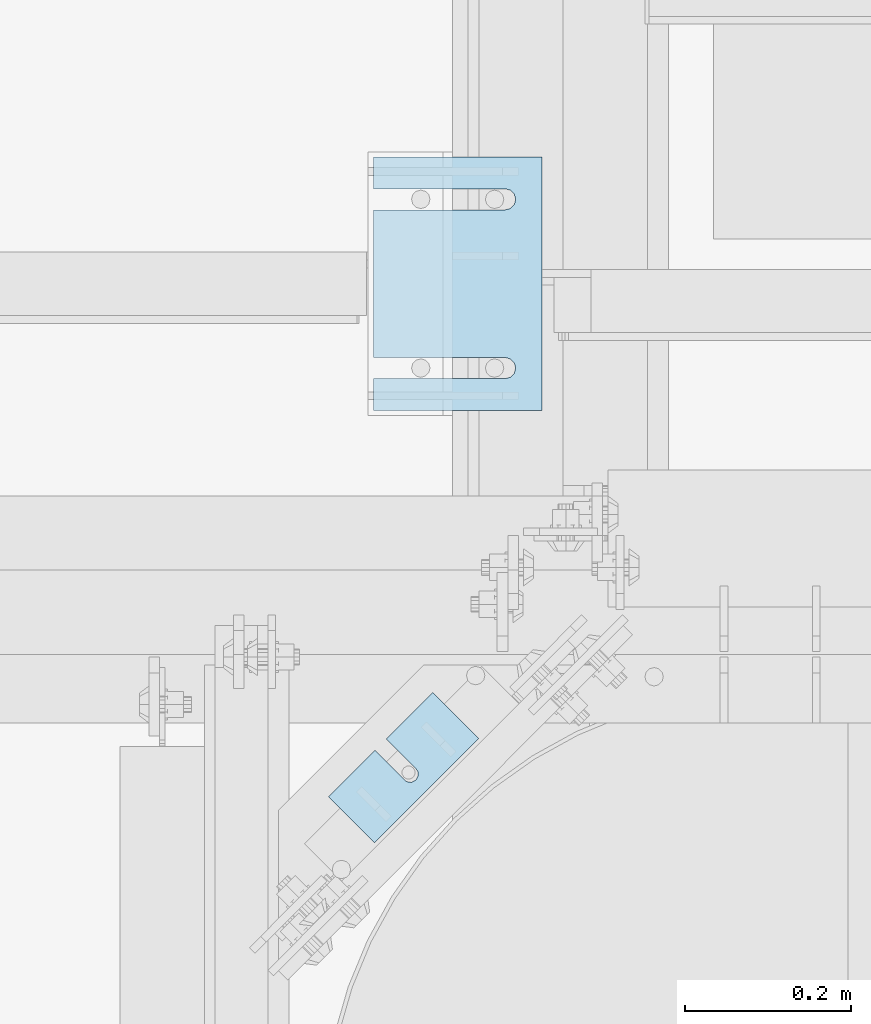
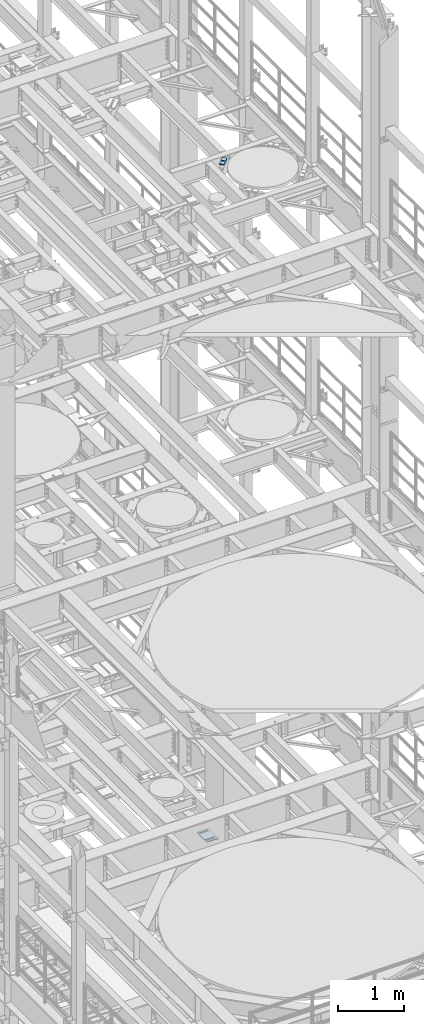
# One storey, part 1657 of 1876: 10 plates, 10 elements without a shape of their own.
"""IFC2X3 building model written with IfcOpenShell, lengths in millimetres."""

from ifc_helpers import new_model, si_unit, frame, origin_with_axes, place, context, subcontext, project, spatial, faceted_brep, material, type_object, element, aggregate, save


model = new_model("IFC2X3")

# Units and contexts
model_context = context("Model", 3, precision=1e-05, world=origin_with_axes())
body_context = subcontext(model_context, "Body", "Model", "MODEL_VIEW")
ifc_project = project(units=[si_unit("LENGTHUNIT", "METRE", prefix="MILLI"), si_unit("AREAUNIT", "SQUARE_METRE"), si_unit("VOLUMEUNIT", "CUBIC_METRE"), si_unit("MASSUNIT", "GRAM", prefix="KILO"), si_unit("TIMEUNIT", "SECOND"), si_unit("PLANEANGLEUNIT", "RADIAN"), si_unit("SOLIDANGLEUNIT", "STERADIAN"), si_unit("THERMODYNAMICTEMPERATUREUNIT", "DEGREE_CELSIUS"), si_unit("LUMINOUSINTENSITYUNIT", "LUMEN")], contexts=[model_context])

# Site, building, storey
site_placement = place(None, origin_with_axes())
site = spatial("IfcSite", under=ifc_project, at=site_placement, CompositionType="ELEMENT")
building_placement = place(site_placement, origin_with_axes())
building = spatial("IfcBuilding", under=site, at=building_placement, Name="Undefined", CompositionType="ELEMENT")
storey_placement = place(building_placement, origin_with_axes())
storey = spatial("IfcBuildingStorey", under=building, at=storey_placement, Name="Undefined", CompositionType="ELEMENT", Elevation=0.0)

# Assembly, plate
assembly_1_placement = place(storey_placement, origin_with_axes())
assembly_1 = element("IfcElementAssembly", 1, at=assembly_1_placement, inside=storey, Name="SHIM PLATE", AssemblyPlace="NOTDEFINED", PredefinedType="RIGID_FRAME")
ifc_material = material(Name="STEEL/A36")
plate_type_1 = type_object("IfcPlateType", PredefinedType="NOTDEFINED")
plate_1_placement = place(assembly_1_placement, frame((6334.01600597448, 4165.55524499807, 18009.3925), z_axis=(0.707106066686187, -0.707107495686186, 0.0), x_axis=(0.707107495686187, 0.707106066686186, 0.0)))
plate_1 = element("IfcPlate", 2, at=plate_1_placement, type_object=plate_type_1, material=ifc_material, Name="SHIM PLATE", context=body_context, shape_type="Brep", body=[
    faceted_brep([(79.3755953647978, -0.793499999999767, -3.63797880709171e-12), (79.3755953647978, 0.793499999999767, -3.63797880709171e-12), (79.3049756952778, 0.793499999999767, 47.6675290359176), (79.3049756952778, -0.793499999999767, 47.6675290359176), (79.4487723981229, 0.793499999999767, 53.7022829617508), (79.4487723981229, -0.793499999999767, 53.7022829617508), (83.063498120483, 0.793499999999767, 58.5368140030459), (83.063498120483, -0.793499999999767, 58.5368140030459), (88.8111609071966, 0.793499999999767, 60.3816188510955), (88.8111609071966, -0.793499999999767, 60.3816188510955), (94.5642614235203, 0.793499999999767, 58.5538423641483), (94.5642614235203, -0.793499999999767, 58.5538423641483), (98.3549540510812, -0.793499999999767, 47.6957349820686), (98.3549540510812, 0.793499999999767, 47.6957349820686), (98.4255737206086, 0.793499999999767, -5.00222085975111e-12), (98.4255737206086, -0.793499999999767, -5.00222085975111e-12), (98.1932875572447, -0.793499999999767, 53.7300366303029), (98.1932875572447, 0.793499999999767, 53.7300366303029), (9.09494701772928e-13, -0.793499999999767, 0.0), (7.93202807471971e-05, -0.793499999999767, 78.4900512695085), (7.93202807471971e-05, 0.793499999999767, 78.4900512695085), (9.09494701772928e-13, 0.793499999999767, 0.0), (177.801101684615, -0.793499999999767, 78.4900512695531), (177.801101684615, 0.793499999999767, 78.4900512695531), (177.801147461002, -0.793499999999767, -8.64019966684282e-12), (177.801147461002, 0.793499999999767, -8.64019966684282e-12)], [[[0, 1, 2, 3]], [[3, 2, 4, 5]], [[5, 4, 6, 7]], [[7, 6, 8, 9]], [[9, 8, 10, 11]], [[12, 13, 14, 15]], [[16, 17, 13, 12]], [[11, 10, 17, 16]], [[18, 19, 20, 21]], [[19, 22, 23, 20]], [[22, 24, 25, 23]], [[25, 24, 15, 14]], [[8, 6, 4, 2, 1, 21, 20, 23, 25, 14, 13, 17, 10]], [[18, 21, 1, 0]], [[15, 24, 22, 19, 18, 0, 3, 5, 7, 9, 11, 16, 12]]]),
])
aggregate(assembly_1, [plate_1])

assembly_2_placement = place(storey_placement, origin_with_axes())
assembly_2 = element("IfcElementAssembly", 3, at=assembly_2_placement, inside=storey, Name="SHIM PLATE", AssemblyPlace="NOTDEFINED", PredefinedType="RIGID_FRAME")
plate_type_2 = type_object("IfcPlateType", PredefinedType="NOTDEFINED")
plate_2_placement = place(assembly_2_placement, frame((6334.01600597448, 4165.55524499807, 18007.0115), z_axis=(0.707106066686187, -0.707107495686186, 0.0), x_axis=(0.707107495686187, 0.707106066686186, 0.0)))
plate_2 = element("IfcPlate", 4, at=plate_2_placement, type_object=plate_type_2, material=ifc_material, Name="SHIM PLATE", context=body_context, shape_type="Brep", body=[
    faceted_brep([(79.3755953647988, -1.58750000000146, -3.18323145620525e-12), (79.3755953647988, 1.58750000000146, -3.18323145620525e-12), (79.3049756952778, 1.58750000000146, 47.6675290359181), (79.3049756952778, -1.58750000000146, 47.6675290359181), (79.4487723981229, 1.58750000000146, 53.7022829617513), (79.4487723981229, -1.58750000000146, 53.7022829617513), (83.0634981204839, 1.58750000000146, 58.5368140030464), (83.0634981204839, -1.58750000000146, 58.5368140030464), (88.8111609071975, 1.58750000000146, 60.3816188510959), (88.8111609071975, -1.58750000000146, 60.3816188510959), (94.5642614235212, 1.58750000000146, 58.5538423641487), (94.5642614235212, -1.58750000000146, 58.5538423641487), (98.3549540510821, -1.58750000000146, 47.6957349820691), (98.3549540510821, 1.58750000000146, 47.6957349820691), (98.4255737206086, 1.58750000000146, -3.63797880709171e-12), (98.4255737206086, -1.58750000000146, -3.63797880709171e-12), (98.1932875572456, -1.58750000000146, 53.7300366303034), (98.1932875572456, 1.58750000000146, 53.7300366303034), (9.09494701772928e-13, -1.58750000000146, 4.54747350886464e-13), (7.93202807471971e-05, -1.58750000000146, 78.490051269509), (7.93202807471971e-05, 1.58750000000146, 78.490051269509), (9.09494701772928e-13, 1.58750000000146, 4.54747350886464e-13), (177.801101684615, -1.58750000000146, 78.4900512695535), (177.801101684615, 1.58750000000146, 78.4900512695535), (177.801147461002, -1.58750000000146, -8.18545231595635e-12), (177.801147461002, 1.58750000000146, -8.18545231595635e-12)], [[[0, 1, 2, 3]], [[3, 2, 4, 5]], [[5, 4, 6, 7]], [[7, 6, 8, 9]], [[9, 8, 10, 11]], [[12, 13, 14, 15]], [[16, 17, 13, 12]], [[11, 10, 17, 16]], [[18, 19, 20, 21]], [[19, 22, 23, 20]], [[22, 24, 25, 23]], [[25, 24, 15, 14]], [[8, 6, 4, 2, 1, 21, 20, 23, 25, 14, 13, 17, 10]], [[18, 21, 1, 0]], [[15, 24, 22, 19, 18, 0, 3, 5, 7, 9, 11, 16, 12]]]),
])
aggregate(assembly_2, [plate_2])

assembly_3_placement = place(storey_placement, origin_with_axes())
assembly_3 = element("IfcElementAssembly", 5, at=assembly_3_placement, inside=storey, Name="SHIM PLATE", AssemblyPlace="NOTDEFINED", PredefinedType="RIGID_FRAME")
plate_3_placement = place(assembly_3_placement, frame((6334.01600597448, 4165.55524499807, 18003.8365), z_axis=(0.707106066686187, -0.707107495686186, 0.0), x_axis=(0.707107495686187, 0.707106066686186, 0.0)))
plate_3 = element("IfcPlate", 6, at=plate_3_placement, type_object=plate_type_2, material=ifc_material, Name="SHIM PLATE", context=body_context, shape_type="Brep", body=[
    faceted_brep([(79.3755953647988, -1.58750000000146, -3.18323145620525e-12), (79.3755953647988, 1.58750000000146, -3.18323145620525e-12), (79.3049756952778, 1.58750000000146, 47.6675290359181), (79.3049756952778, -1.58750000000146, 47.6675290359181), (79.4487723981229, 1.58750000000146, 53.7022829617513), (79.4487723981229, -1.58750000000146, 53.7022829617513), (83.0634981204839, 1.58750000000146, 58.5368140030464), (83.0634981204839, -1.58750000000146, 58.5368140030464), (88.8111609071975, 1.58750000000146, 60.3816188510959), (88.8111609071975, -1.58750000000146, 60.3816188510959), (94.5642614235212, 1.58750000000146, 58.5538423641487), (94.5642614235212, -1.58750000000146, 58.5538423641487), (98.3549540510821, -1.58750000000146, 47.6957349820691), (98.3549540510821, 1.58750000000146, 47.6957349820691), (98.4255737206086, 1.58750000000146, -3.63797880709171e-12), (98.4255737206086, -1.58750000000146, -3.63797880709171e-12), (98.1932875572456, -1.58750000000146, 53.7300366303034), (98.1932875572456, 1.58750000000146, 53.7300366303034), (9.09494701772928e-13, -1.58750000000146, 4.54747350886464e-13), (7.93202807471971e-05, -1.58750000000146, 78.490051269509), (7.93202807471971e-05, 1.58750000000146, 78.490051269509), (9.09494701772928e-13, 1.58750000000146, 4.54747350886464e-13), (177.801101684615, -1.58750000000146, 78.4900512695535), (177.801101684615, 1.58750000000146, 78.4900512695535), (177.801147461002, -1.58750000000146, -8.18545231595635e-12), (177.801147461002, 1.58750000000146, -8.18545231595635e-12)], [[[0, 1, 2, 3]], [[3, 2, 4, 5]], [[5, 4, 6, 7]], [[7, 6, 8, 9]], [[9, 8, 10, 11]], [[12, 13, 14, 15]], [[16, 17, 13, 12]], [[11, 10, 17, 16]], [[18, 19, 20, 21]], [[19, 22, 23, 20]], [[22, 24, 25, 23]], [[25, 24, 15, 14]], [[8, 6, 4, 2, 1, 21, 20, 23, 25, 14, 13, 17, 10]], [[18, 21, 1, 0]], [[15, 24, 22, 19, 18, 0, 3, 5, 7, 9, 11, 16, 12]]]),
])
aggregate(assembly_3, [plate_3])

assembly_4_placement = place(storey_placement, origin_with_axes())
assembly_4 = element("IfcElementAssembly", 7, at=assembly_4_placement, inside=storey, Name="SHIM PLATE", AssemblyPlace="NOTDEFINED", PredefinedType="RIGID_FRAME")
plate_type_3 = type_object("IfcPlateType", PredefinedType="NOTDEFINED")
plate_4_placement = place(assembly_4_placement, frame((6334.01600597448, 4165.55524499807, 17999.868), z_axis=(0.707106066686187, -0.707107495686186, 0.0), x_axis=(0.707107495686187, 0.707106066686186, 0.0)))
plate_4 = element("IfcPlate", 8, at=plate_4_placement, type_object=plate_type_3, material=ifc_material, Name="SHIM PLATE", context=body_context, shape_type="Brep", body=[
    faceted_brep([(79.3755953647969, -2.38100000000122, -3.18323145620525e-12), (79.3755953647969, 2.38100000000122, -3.18323145620525e-12), (79.3049756952778, 2.38100000000122, 47.6675290359181), (79.3049756952778, -2.38100000000122, 47.6675290359181), (79.4487723981229, 2.38100000000122, 53.7022829617513), (79.4487723981229, -2.38100000000122, 53.7022829617513), (83.063498120483, 2.38100000000122, 58.5368140030464), (83.063498120483, -2.38100000000122, 58.5368140030464), (88.8111609071966, 2.38100000000122, 60.3816188510959), (88.8111609071966, -2.38100000000122, 60.3816188510959), (94.5642614235203, 2.38100000000122, 58.5538423641487), (94.5642614235203, -2.38100000000122, 58.5538423641487), (98.3549540510821, -2.38100000000122, 47.6957349820691), (98.3549540510821, 2.38100000000122, 47.6957349820691), (98.4255737206086, 2.38100000000122, -4.54747350886464e-12), (98.4255737206086, -2.38100000000122, -4.54747350886464e-12), (98.1932875572447, -2.38100000000122, 53.7300366303034), (98.1932875572447, 2.38100000000122, 53.7300366303034), (0.0, -2.38100000000122, 4.54747350886464e-13), (7.93202807471971e-05, -2.38100000000122, 78.4900512695094), (7.93202807471971e-05, 2.38100000000122, 78.4900512695094), (0.0, 2.38100000000122, 4.54747350886464e-13), (177.801101684615, -2.38100000000122, 78.4900512695526), (177.801101684615, 2.38100000000122, 78.4900512695526), (177.801147461, -2.38100000000122, -7.73070496506989e-12), (177.801147461, 2.38100000000122, -7.73070496506989e-12)], [[[0, 1, 2, 3]], [[3, 2, 4, 5]], [[5, 4, 6, 7]], [[7, 6, 8, 9]], [[9, 8, 10, 11]], [[12, 13, 14, 15]], [[16, 17, 13, 12]], [[11, 10, 17, 16]], [[18, 19, 20, 21]], [[19, 22, 23, 20]], [[22, 24, 25, 23]], [[25, 24, 15, 14]], [[8, 6, 4, 2, 1, 21, 20, 23, 25, 14, 13, 17, 10]], [[18, 21, 1, 0]], [[15, 24, 22, 19, 18, 0, 3, 5, 7, 9, 11, 16, 12]]]),
])
aggregate(assembly_4, [plate_4])

assembly_5_placement = place(storey_placement, origin_with_axes())
assembly_5 = element("IfcElementAssembly", 9, at=assembly_5_placement, inside=storey, Name="SHIM PLATE", AssemblyPlace="NOTDEFINED", PredefinedType="RIGID_FRAME")
plate_5_placement = place(assembly_5_placement, frame((6334.01600597448, 4165.55524499807, 17995.106), z_axis=(0.707106066686187, -0.707107495686186, 0.0), x_axis=(0.707107495686187, 0.707106066686186, 0.0)))
plate_5 = element("IfcPlate", 10, at=plate_5_placement, type_object=plate_type_3, material=ifc_material, Name="SHIM PLATE", context=body_context, shape_type="Brep", body=[
    faceted_brep([(79.3755953647969, -2.38100000000122, -3.18323145620525e-12), (79.3755953647969, 2.38100000000122, -3.18323145620525e-12), (79.3049756952778, 2.38100000000122, 47.6675290359181), (79.3049756952778, -2.38100000000122, 47.6675290359181), (79.4487723981229, 2.38100000000122, 53.7022829617513), (79.4487723981229, -2.38100000000122, 53.7022829617513), (83.063498120483, 2.38100000000122, 58.5368140030464), (83.063498120483, -2.38100000000122, 58.5368140030464), (88.8111609071966, 2.38100000000122, 60.3816188510959), (88.8111609071966, -2.38100000000122, 60.3816188510959), (94.5642614235203, 2.38100000000122, 58.5538423641487), (94.5642614235203, -2.38100000000122, 58.5538423641487), (98.3549540510821, -2.38100000000122, 47.6957349820691), (98.3549540510821, 2.38100000000122, 47.6957349820691), (98.4255737206086, 2.38100000000122, -4.54747350886464e-12), (98.4255737206086, -2.38100000000122, -4.54747350886464e-12), (98.1932875572447, -2.38100000000122, 53.7300366303034), (98.1932875572447, 2.38100000000122, 53.7300366303034), (0.0, -2.38100000000122, 4.54747350886464e-13), (7.93202807471971e-05, -2.38100000000122, 78.4900512695094), (7.93202807471971e-05, 2.38100000000122, 78.4900512695094), (0.0, 2.38100000000122, 4.54747350886464e-13), (177.801101684615, -2.38100000000122, 78.4900512695526), (177.801101684615, 2.38100000000122, 78.4900512695526), (177.801147461, -2.38100000000122, -7.73070496506989e-12), (177.801147461, 2.38100000000122, -7.73070496506989e-12)], [[[0, 1, 2, 3]], [[3, 2, 4, 5]], [[5, 4, 6, 7]], [[7, 6, 8, 9]], [[9, 8, 10, 11]], [[12, 13, 14, 15]], [[16, 17, 13, 12]], [[11, 10, 17, 16]], [[18, 19, 20, 21]], [[19, 22, 23, 20]], [[22, 24, 25, 23]], [[25, 24, 15, 14]], [[8, 6, 4, 2, 1, 21, 20, 23, 25, 14, 13, 17, 10]], [[18, 21, 1, 0]], [[15, 24, 22, 19, 18, 0, 3, 5, 7, 9, 11, 16, 12]]]),
])
aggregate(assembly_5, [plate_5])

assembly_6_placement = place(storey_placement, origin_with_axes())
assembly_6 = element("IfcElementAssembly", 11, at=assembly_6_placement, inside=storey, Name="SHIM PLATE", AssemblyPlace="NOTDEFINED", PredefinedType="RIGID_FRAME")
plate_type_4 = type_object("IfcPlateType", PredefinedType="NOTDEFINED")
plate_6_placement = place(assembly_6_placement, frame((6591.29886176445, 4935.78240966797, 5156.9925), z_axis=(0.0, -1.0, 0.0), x_axis=(-1.0, 0.0, 0.0)))
plate_6 = element("IfcPlate", 12, at=plate_6_placement, type_object=plate_type_4, material=ifc_material, Name="SHIM PLATE", context=body_context, shape_type="Brep", body=[
    faceted_brep([(203.203060149864, -0.793499999999767, 38.103375484061), (203.203060149864, 0.793499999999767, 38.103375484061), (44.4515180349072, 0.793499999999767, 38.1033599194234), (44.4515180349072, -0.793499999999767, 38.1033599194234), (38.1012989900946, 0.793499999999767, 39.8049650059329), (38.1012989900946, -0.793499999999767, 39.8049650059329), (33.4527432566938, 0.793499999999767, 44.4538004924834), (33.4527432566938, -0.793499999999767, 44.4538004924834), (31.7515203221337, 0.793499999999767, 50.8041219264314), (31.7515203221337, -0.793499999999767, 50.8041219264314), (33.4535054350818, 0.793499999999767, 57.1542391271487), (33.4535054350818, -0.793499999999767, 57.1542391271487), (38.1026191065821, 0.793499999999767, 61.8025166422076), (38.1026191065821, -0.793499999999767, 61.8025166422076), (44.4530423390133, 0.793499999999767, 63.5033595381083), (44.4530423390133, -0.793499999999767, 63.5033595381083), (203.203057597802, -0.793499999999767, 63.5033693805453), (203.203057606771, 0.793499999999767, 63.5033693805453), (203.203063964842, -0.793499999999767, -8.45830072648823e-11), (9.09494701772928e-13, -0.793499999999767, 0.0), (9.09494701772928e-13, 0.793499999999767, 0.0), (203.203063964842, 0.793499999999767, -8.45830072648823e-11), (-1.83106603799388e-05, -0.793499999999767, 304.8037109375), (-1.83106603799388e-05, 0.793499999999767, 304.8037109375), (203.203033447349, -0.793499999999767, 304.803710937444), (203.203033447349, 0.793499999999767, 304.803710937444), (203.20303725321, -0.793499999999767, 266.701819087575), (203.203037262178, 0.793499999999767, 266.701819087575), (44.4530372532099, -0.793499999999767, 266.701809245139), (44.4530372532099, 0.793499999999767, 266.701809245139), (38.1026140207787, -0.793499999999767, 265.000966349239), (38.1026140207787, 0.793499999999767, 265.000966349239), (33.4535003492774, -0.793499999999767, 260.352688834179), (33.4535003492774, 0.793499999999767, 260.352688834179), (31.7515152363312, -0.793499999999767, 254.002571633462), (31.7515152363312, 0.793499999999767, 254.002571633462), (33.4527381708904, -0.793499999999767, 247.652250199514), (33.4527381708904, 0.793499999999767, 247.652250199514), (38.1012939042912, -0.793499999999767, 243.003414712964), (38.1012939042912, 0.793499999999767, 243.003414712964), (44.4515129491037, -0.793499999999767, 241.301809626454), (44.4515129491037, 0.793499999999767, 241.301809626454), (203.203039805271, -0.793499999999767, 241.301825191091), (203.203039805271, 0.793499999999767, 241.301825191091)], [[[0, 1, 2, 3]], [[3, 2, 4, 5]], [[5, 4, 6, 7]], [[7, 6, 8, 9]], [[9, 8, 10, 11]], [[11, 10, 12, 13]], [[13, 12, 14, 15]], [[16, 15, 14, 17]], [[18, 19, 20, 21]], [[19, 22, 23, 20]], [[22, 24, 25, 23]], [[25, 24, 26, 27]], [[26, 28, 29, 27]], [[30, 31, 29, 28]], [[32, 33, 31, 30]], [[34, 35, 33, 32]], [[36, 37, 35, 34]], [[38, 39, 37, 36]], [[40, 41, 39, 38]], [[42, 43, 41, 40]], [[43, 42, 16, 17]], [[12, 10, 8, 6, 4, 2, 1, 21, 20, 23, 25, 27, 29, 31, 33, 35, 37, 39, 41, 43, 17, 14]], [[18, 21, 1, 0]], [[42, 40, 38, 36, 34, 32, 30, 28, 26, 24, 22, 19, 18, 0, 3, 5, 7, 9, 11, 13, 15, 16]]]),
])
aggregate(assembly_6, [plate_6])

assembly_7_placement = place(storey_placement, origin_with_axes())
assembly_7 = element("IfcElementAssembly", 13, at=assembly_7_placement, inside=storey, Name="SHIM PLATE", AssemblyPlace="NOTDEFINED", PredefinedType="RIGID_FRAME")
plate_type_5 = type_object("IfcPlateType", PredefinedType="NOTDEFINED")
plate_7_placement = place(assembly_7_placement, frame((6591.29886176445, 4935.78240966797, 5154.6115), z_axis=(0.0, -1.0, 0.0), x_axis=(-1.0, 0.0, 0.0)))
plate_7 = element("IfcPlate", 14, at=plate_7_placement, type_object=plate_type_5, material=ifc_material, Name="SHIM PLATE", context=body_context, shape_type="Brep", body=[
    faceted_brep([(203.203060149865, -1.58749999999964, 38.1033754840619), (203.203060149865, 1.58749999999964, 38.1033754840619), (44.4515180349081, 1.58749999999964, 38.1033599194243), (44.4515180349081, -1.58749999999964, 38.1033599194243), (38.1012989900955, 1.58749999999964, 39.8049650059338), (38.1012989900955, -1.58749999999964, 39.8049650059338), (33.4527432566947, 1.58749999999964, 44.4538004924843), (33.4527432566947, -1.58749999999964, 44.4538004924843), (31.7515203221346, 1.58749999999964, 50.8041219264323), (31.7515203221346, -1.58749999999964, 50.8041219264323), (33.4535054350827, 1.58749999999964, 57.1542391271496), (33.4535054350827, -1.58749999999964, 57.1542391271496), (38.102619106583, 1.58749999999964, 61.8025166422085), (38.102619106583, -1.58749999999964, 61.8025166422085), (44.4530423390142, 1.58749999999964, 63.5033595381092), (44.4530423390142, -1.58749999999964, 63.5033595381092), (203.203057597803, -1.58749999999964, 63.5033693805462), (203.203057606772, 1.58749999999964, 63.5033693805462), (203.203063964843, -1.58749999999964, -8.36735125631094e-11), (9.09494701772928e-13, -1.58750000000146, 4.54747350886464e-13), (9.09494701772928e-13, 1.58750000000146, 4.54747350886464e-13), (203.203063964843, 1.58749999999964, -8.36735125631094e-11), (-1.83106631084229e-05, -1.58749999999964, 304.803710937501), (-1.83106631084229e-05, 1.58749999999964, 304.803710937501), (203.20303344735, -1.58749999999964, 304.803710937445), (203.20303344735, 1.58749999999964, 304.803710937445), (203.203037253211, -1.58749999999964, 266.701819087576), (203.203037262179, 1.58749999999964, 266.701819087576), (44.4530372532108, -1.58749999999964, 266.70180924514), (44.4530372532108, 1.58749999999964, 266.70180924514), (38.1026140207796, -1.58749999999964, 265.00096634924), (38.1026140207796, 1.58749999999964, 265.00096634924), (33.4535003492783, -1.58749999999964, 260.35268883418), (33.4535003492783, 1.58749999999964, 260.35268883418), (31.7515152363321, -1.58749999999964, 254.002571633463), (31.7515152363321, 1.58749999999964, 254.002571633463), (33.4527381708913, -1.58749999999964, 247.652250199515), (33.4527381708913, 1.58749999999964, 247.652250199515), (38.1012939042921, -1.58749999999964, 243.003414712965), (38.1012939042921, 1.58749999999964, 243.003414712965), (44.4515129491047, -1.58749999999964, 241.301809626455), (44.4515129491047, 1.58749999999964, 241.301809626455), (203.203039805272, -1.58749999999964, 241.301825191092), (203.203039805272, 1.58749999999964, 241.301825191092)], [[[0, 1, 2, 3]], [[3, 2, 4, 5]], [[5, 4, 6, 7]], [[7, 6, 8, 9]], [[9, 8, 10, 11]], [[11, 10, 12, 13]], [[13, 12, 14, 15]], [[16, 15, 14, 17]], [[18, 19, 20, 21]], [[19, 22, 23, 20]], [[22, 24, 25, 23]], [[25, 24, 26, 27]], [[26, 28, 29, 27]], [[30, 31, 29, 28]], [[32, 33, 31, 30]], [[34, 35, 33, 32]], [[36, 37, 35, 34]], [[38, 39, 37, 36]], [[40, 41, 39, 38]], [[42, 43, 41, 40]], [[43, 42, 16, 17]], [[12, 10, 8, 6, 4, 2, 1, 21, 20, 23, 25, 27, 29, 31, 33, 35, 37, 39, 41, 43, 17, 14]], [[18, 21, 1, 0]], [[42, 40, 38, 36, 34, 32, 30, 28, 26, 24, 22, 19, 18, 0, 3, 5, 7, 9, 11, 13, 15, 16]]]),
])
aggregate(assembly_7, [plate_7])

assembly_8_placement = place(storey_placement, origin_with_axes())
assembly_8 = element("IfcElementAssembly", 15, at=assembly_8_placement, inside=storey, Name="SHIM PLATE", AssemblyPlace="NOTDEFINED", PredefinedType="RIGID_FRAME")
plate_8_placement = place(assembly_8_placement, frame((6591.29886176445, 4935.78240966797, 5151.4365), z_axis=(0.0, -1.0, 0.0), x_axis=(-1.0, 0.0, 0.0)))
plate_8 = element("IfcPlate", 16, at=plate_8_placement, type_object=plate_type_5, material=ifc_material, Name="SHIM PLATE", context=body_context, shape_type="Brep", body=[
    faceted_brep([(203.203060149865, -1.58749999999964, 38.1033754840619), (203.203060149865, 1.58749999999964, 38.1033754840619), (44.4515180349081, 1.58749999999964, 38.1033599194243), (44.4515180349081, -1.58749999999964, 38.1033599194243), (38.1012989900955, 1.58749999999964, 39.8049650059338), (38.1012989900955, -1.58749999999964, 39.8049650059338), (33.4527432566947, 1.58749999999964, 44.4538004924843), (33.4527432566947, -1.58749999999964, 44.4538004924843), (31.7515203221346, 1.58749999999964, 50.8041219264323), (31.7515203221346, -1.58749999999964, 50.8041219264323), (33.4535054350827, 1.58749999999964, 57.1542391271496), (33.4535054350827, -1.58749999999964, 57.1542391271496), (38.102619106583, 1.58749999999964, 61.8025166422085), (38.102619106583, -1.58749999999964, 61.8025166422085), (44.4530423390142, 1.58749999999964, 63.5033595381092), (44.4530423390142, -1.58749999999964, 63.5033595381092), (203.203057597803, -1.58749999999964, 63.5033693805462), (203.203057606772, 1.58749999999964, 63.5033693805462), (203.203063964843, -1.58749999999964, -8.36735125631094e-11), (9.09494701772928e-13, -1.58750000000146, 4.54747350886464e-13), (9.09494701772928e-13, 1.58750000000146, 4.54747350886464e-13), (203.203063964843, 1.58749999999964, -8.36735125631094e-11), (-1.83106631084229e-05, -1.58749999999964, 304.803710937501), (-1.83106631084229e-05, 1.58749999999964, 304.803710937501), (203.20303344735, -1.58749999999964, 304.803710937445), (203.20303344735, 1.58749999999964, 304.803710937445), (203.203037253211, -1.58749999999964, 266.701819087576), (203.203037262179, 1.58749999999964, 266.701819087576), (44.4530372532108, -1.58749999999964, 266.70180924514), (44.4530372532108, 1.58749999999964, 266.70180924514), (38.1026140207796, -1.58749999999964, 265.00096634924), (38.1026140207796, 1.58749999999964, 265.00096634924), (33.4535003492783, -1.58749999999964, 260.35268883418), (33.4535003492783, 1.58749999999964, 260.35268883418), (31.7515152363321, -1.58749999999964, 254.002571633463), (31.7515152363321, 1.58749999999964, 254.002571633463), (33.4527381708913, -1.58749999999964, 247.652250199515), (33.4527381708913, 1.58749999999964, 247.652250199515), (38.1012939042921, -1.58749999999964, 243.003414712965), (38.1012939042921, 1.58749999999964, 243.003414712965), (44.4515129491047, -1.58749999999964, 241.301809626455), (44.4515129491047, 1.58749999999964, 241.301809626455), (203.203039805272, -1.58749999999964, 241.301825191092), (203.203039805272, 1.58749999999964, 241.301825191092)], [[[0, 1, 2, 3]], [[3, 2, 4, 5]], [[5, 4, 6, 7]], [[7, 6, 8, 9]], [[9, 8, 10, 11]], [[11, 10, 12, 13]], [[13, 12, 14, 15]], [[16, 15, 14, 17]], [[18, 19, 20, 21]], [[19, 22, 23, 20]], [[22, 24, 25, 23]], [[25, 24, 26, 27]], [[26, 28, 29, 27]], [[30, 31, 29, 28]], [[32, 33, 31, 30]], [[34, 35, 33, 32]], [[36, 37, 35, 34]], [[38, 39, 37, 36]], [[40, 41, 39, 38]], [[42, 43, 41, 40]], [[43, 42, 16, 17]], [[12, 10, 8, 6, 4, 2, 1, 21, 20, 23, 25, 27, 29, 31, 33, 35, 37, 39, 41, 43, 17, 14]], [[18, 21, 1, 0]], [[42, 40, 38, 36, 34, 32, 30, 28, 26, 24, 22, 19, 18, 0, 3, 5, 7, 9, 11, 13, 15, 16]]]),
])
aggregate(assembly_8, [plate_8])

assembly_9_placement = place(storey_placement, origin_with_axes())
assembly_9 = element("IfcElementAssembly", 17, at=assembly_9_placement, inside=storey, Name="SHIM PLATE", AssemblyPlace="NOTDEFINED", PredefinedType="RIGID_FRAME")
plate_type_6 = type_object("IfcPlateType", PredefinedType="NOTDEFINED")
plate_9_placement = place(assembly_9_placement, frame((6591.29886176445, 4935.78240966797, 5147.468), z_axis=(0.0, -1.0, 0.0), x_axis=(-1.0, 0.0, 0.0)))
plate_9 = element("IfcPlate", 18, at=plate_9_placement, type_object=plate_type_6, material=ifc_material, Name="SHIM PLATE", context=body_context, shape_type="Brep", body=[
    faceted_brep([(203.203060149865, -2.38100000000031, 38.1033754840619), (203.203060149865, 2.38100000000031, 38.1033754840619), (44.4515180349081, 2.38100000000031, 38.1033599194243), (44.4515180349081, -2.38100000000031, 38.1033599194243), (38.1012989900955, 2.38100000000031, 39.8049650059338), (38.1012989900955, -2.38100000000031, 39.8049650059338), (33.4527432566947, 2.38100000000031, 44.4538004924843), (33.4527432566947, -2.38100000000031, 44.4538004924843), (31.7515203221346, 2.38100000000031, 50.8041219264323), (31.7515203221346, -2.38100000000031, 50.8041219264323), (33.4535054350827, 2.38100000000031, 57.1542391271496), (33.4535054350827, -2.38100000000031, 57.1542391271496), (38.102619106583, 2.38100000000031, 61.8025166422085), (38.102619106583, -2.38100000000031, 61.8025166422085), (44.4530423390142, 2.38100000000031, 63.5033595381092), (44.4530423390142, -2.38100000000031, 63.5033595381092), (203.203057597803, -2.38100000000031, 63.5033693805462), (203.203057606772, 2.38100000000031, 63.5033693805462), (203.203063964843, -2.38100000000031, -8.36735125631094e-11), (0.0, -2.38100000000122, 4.54747350886464e-13), (0.0, 2.38100000000122, 4.54747350886464e-13), (203.203063964843, 2.38100000000031, -8.36735125631094e-11), (-1.83106667464017e-05, -2.38100000000031, 304.803710937501), (-1.83106667464017e-05, 2.38100000000031, 304.803710937501), (203.20303344735, -2.38100000000031, 304.803710937445), (203.20303344735, 2.38100000000031, 304.803710937445), (203.203037253211, -2.38100000000031, 266.701819087576), (203.203037262179, 2.38100000000031, 266.701819087576), (44.4530372532108, -2.38100000000031, 266.70180924514), (44.4530372532108, 2.38100000000031, 266.70180924514), (38.1026140207796, -2.38100000000031, 265.00096634924), (38.1026140207796, 2.38100000000031, 265.00096634924), (33.4535003492783, -2.38100000000031, 260.35268883418), (33.4535003492783, 2.38100000000031, 260.35268883418), (31.7515152363321, -2.38100000000031, 254.002571633463), (31.7515152363321, 2.38100000000031, 254.002571633463), (33.4527381708913, -2.38100000000031, 247.652250199515), (33.4527381708913, 2.38100000000031, 247.652250199515), (38.1012939042921, -2.38100000000031, 243.003414712965), (38.1012939042921, 2.38100000000031, 243.003414712965), (44.4515129491047, -2.38100000000031, 241.301809626455), (44.4515129491047, 2.38100000000031, 241.301809626455), (203.203039805272, -2.38100000000031, 241.301825191092), (203.203039805272, 2.38100000000031, 241.301825191092)], [[[0, 1, 2, 3]], [[3, 2, 4, 5]], [[5, 4, 6, 7]], [[7, 6, 8, 9]], [[9, 8, 10, 11]], [[11, 10, 12, 13]], [[13, 12, 14, 15]], [[16, 15, 14, 17]], [[18, 19, 20, 21]], [[19, 22, 23, 20]], [[22, 24, 25, 23]], [[25, 24, 26, 27]], [[26, 28, 29, 27]], [[30, 31, 29, 28]], [[32, 33, 31, 30]], [[34, 35, 33, 32]], [[36, 37, 35, 34]], [[38, 39, 37, 36]], [[40, 41, 39, 38]], [[42, 43, 41, 40]], [[43, 42, 16, 17]], [[12, 10, 8, 6, 4, 2, 1, 21, 20, 23, 25, 27, 29, 31, 33, 35, 37, 39, 41, 43, 17, 14]], [[18, 21, 1, 0]], [[42, 40, 38, 36, 34, 32, 30, 28, 26, 24, 22, 19, 18, 0, 3, 5, 7, 9, 11, 13, 15, 16]]]),
])
aggregate(assembly_9, [plate_9])

assembly_10_placement = place(storey_placement, origin_with_axes())
assembly_10 = element("IfcElementAssembly", 19, at=assembly_10_placement, inside=storey, Name="SHIM PLATE", AssemblyPlace="NOTDEFINED", PredefinedType="RIGID_FRAME")
plate_10_placement = place(assembly_10_placement, frame((6591.29886176445, 4935.78240966797, 5142.706), z_axis=(0.0, -1.0, 0.0), x_axis=(-1.0, 0.0, 0.0)))
plate_10 = element("IfcPlate", 20, at=plate_10_placement, type_object=plate_type_6, material=ifc_material, Name="SHIM PLATE", context=body_context, shape_type="Brep", body=[
    faceted_brep([(203.203060149865, -2.38100000000031, 38.1033754840619), (203.203060149865, 2.38100000000031, 38.1033754840619), (44.4515180349081, 2.38100000000031, 38.1033599194243), (44.4515180349081, -2.38100000000031, 38.1033599194243), (38.1012989900955, 2.38100000000031, 39.8049650059338), (38.1012989900955, -2.38100000000031, 39.8049650059338), (33.4527432566947, 2.38100000000031, 44.4538004924843), (33.4527432566947, -2.38100000000031, 44.4538004924843), (31.7515203221346, 2.38100000000031, 50.8041219264323), (31.7515203221346, -2.38100000000031, 50.8041219264323), (33.4535054350827, 2.38100000000031, 57.1542391271496), (33.4535054350827, -2.38100000000031, 57.1542391271496), (38.102619106583, 2.38100000000031, 61.8025166422085), (38.102619106583, -2.38100000000031, 61.8025166422085), (44.4530423390142, 2.38100000000031, 63.5033595381092), (44.4530423390142, -2.38100000000031, 63.5033595381092), (203.203057597803, -2.38100000000031, 63.5033693805462), (203.203057606772, 2.38100000000031, 63.5033693805462), (203.203063964843, -2.38100000000031, -8.36735125631094e-11), (0.0, -2.38100000000122, 4.54747350886464e-13), (0.0, 2.38100000000122, 4.54747350886464e-13), (203.203063964843, 2.38100000000031, -8.36735125631094e-11), (-1.83106667464017e-05, -2.38100000000031, 304.803710937501), (-1.83106667464017e-05, 2.38100000000031, 304.803710937501), (203.20303344735, -2.38100000000031, 304.803710937445), (203.20303344735, 2.38100000000031, 304.803710937445), (203.203037253211, -2.38100000000031, 266.701819087576), (203.203037262179, 2.38100000000031, 266.701819087576), (44.4530372532108, -2.38100000000031, 266.70180924514), (44.4530372532108, 2.38100000000031, 266.70180924514), (38.1026140207796, -2.38100000000031, 265.00096634924), (38.1026140207796, 2.38100000000031, 265.00096634924), (33.4535003492783, -2.38100000000031, 260.35268883418), (33.4535003492783, 2.38100000000031, 260.35268883418), (31.7515152363321, -2.38100000000031, 254.002571633463), (31.7515152363321, 2.38100000000031, 254.002571633463), (33.4527381708913, -2.38100000000031, 247.652250199515), (33.4527381708913, 2.38100000000031, 247.652250199515), (38.1012939042921, -2.38100000000031, 243.003414712965), (38.1012939042921, 2.38100000000031, 243.003414712965), (44.4515129491047, -2.38100000000031, 241.301809626455), (44.4515129491047, 2.38100000000031, 241.301809626455), (203.203039805272, -2.38100000000031, 241.301825191092), (203.203039805272, 2.38100000000031, 241.301825191092)], [[[0, 1, 2, 3]], [[3, 2, 4, 5]], [[5, 4, 6, 7]], [[7, 6, 8, 9]], [[9, 8, 10, 11]], [[11, 10, 12, 13]], [[13, 12, 14, 15]], [[16, 15, 14, 17]], [[18, 19, 20, 21]], [[19, 22, 23, 20]], [[22, 24, 25, 23]], [[25, 24, 26, 27]], [[26, 28, 29, 27]], [[30, 31, 29, 28]], [[32, 33, 31, 30]], [[34, 35, 33, 32]], [[36, 37, 35, 34]], [[38, 39, 37, 36]], [[40, 41, 39, 38]], [[42, 43, 41, 40]], [[43, 42, 16, 17]], [[12, 10, 8, 6, 4, 2, 1, 21, 20, 23, 25, 27, 29, 31, 33, 35, 37, 39, 41, 43, 17, 14]], [[18, 21, 1, 0]], [[42, 40, 38, 36, 34, 32, 30, 28, 26, 24, 22, 19, 18, 0, 3, 5, 7, 9, 11, 13, 15, 16]]]),
])
aggregate(assembly_10, [plate_10])

save(model, "model.ifc")
